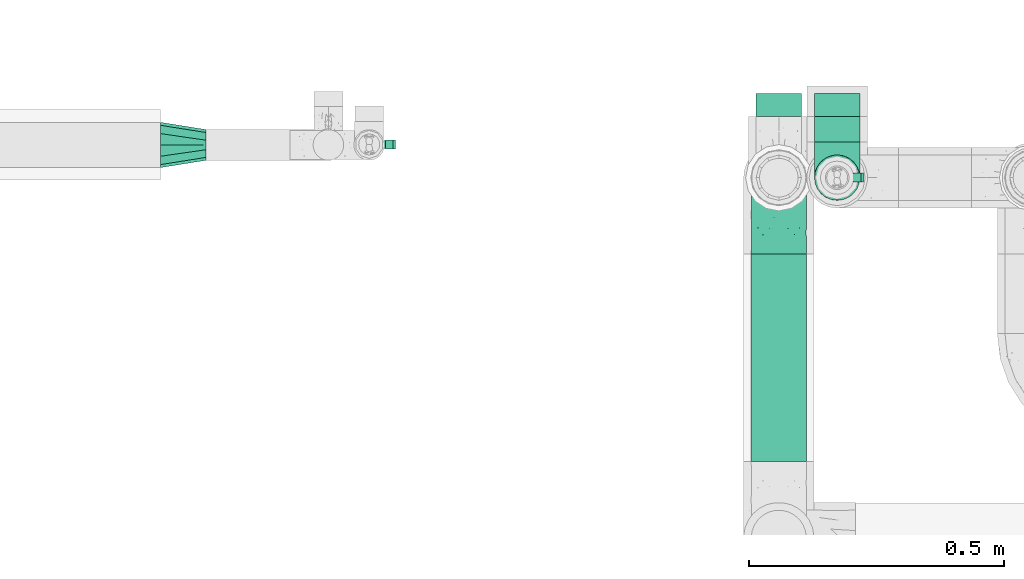
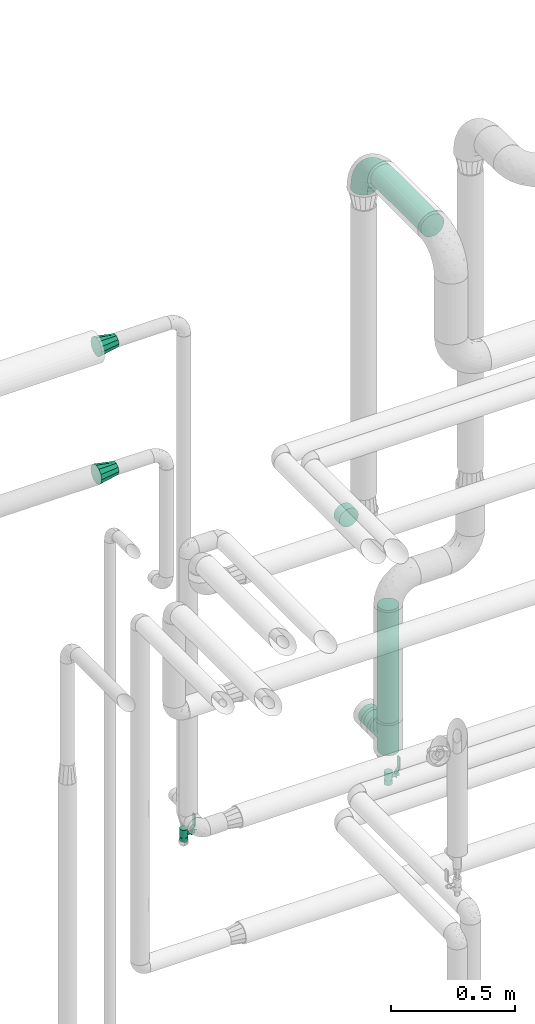
# One storey, part 719 of 827: 6 flow fittings, 3 flow segments, 2 flow controllers.
"""IFC2X3 building model written with IfcOpenShell, lengths in millimetres."""

from ifc_helpers import new_model, entity, si_unit, converted_unit, derived_unit, direction, frame, origin, origin_2d_with_axis, place, context, subcontext, project, spatial, polyline, circle, outline, extrude, faceted_brep, source, transform, mapped, material, material_list, type_object, type_shapes, element, save


model = new_model("IFC2X3")

# Units and contexts
model_context = context("Model", 3, precision=0.01, world=origin(), true_north=direction((6.12303176911189e-17, 1.0)))
body_context = subcontext(model_context, "Body", "Model", "MODEL_VIEW")
ifc_project = project(units=[si_unit("LENGTHUNIT", "METRE", prefix="MILLI"), si_unit("AREAUNIT", "SQUARE_METRE"), si_unit("VOLUMEUNIT", "CUBIC_METRE"), converted_unit("PLANEANGLEUNIT", "DEGREE", entity("IfcRatioMeasure", 0.0174532925199433), si_unit("PLANEANGLEUNIT", "RADIAN"), dimensions=[0, 0, 0, 0, 0, 0, 0]), si_unit("MASSUNIT", "GRAM", prefix="KILO"), derived_unit("MASSDENSITYUNIT", [(si_unit("MASSUNIT", "GRAM", prefix="KILO"), 1), (si_unit("LENGTHUNIT", "METRE"), -3)]), derived_unit("MOMENTOFINERTIAUNIT", [(si_unit("LENGTHUNIT", "METRE"), 4)]), si_unit("TIMEUNIT", "SECOND"), si_unit("FREQUENCYUNIT", "HERTZ"), si_unit("THERMODYNAMICTEMPERATUREUNIT", "DEGREE_CELSIUS"), derived_unit("THERMALTRANSMITTANCEUNIT", [(si_unit("MASSUNIT", "GRAM", prefix="KILO"), 1), (si_unit("THERMODYNAMICTEMPERATUREUNIT", "KELVIN"), -1), (si_unit("TIMEUNIT", "SECOND"), -3)]), derived_unit("VOLUMETRICFLOWRATEUNIT", [(si_unit("LENGTHUNIT", "METRE"), 3), (si_unit("TIMEUNIT", "SECOND"), -1)]), derived_unit("MASSFLOWRATEUNIT", [(si_unit("MASSUNIT", "GRAM", prefix="KILO"), 1), (si_unit("TIMEUNIT", "SECOND"), -1)]), derived_unit("ROTATIONALFREQUENCYUNIT", [(si_unit("TIMEUNIT", "SECOND"), -1)]), si_unit("ELECTRICCURRENTUNIT", "AMPERE"), si_unit("ELECTRICVOLTAGEUNIT", "VOLT"), si_unit("POWERUNIT", "WATT"), si_unit("FORCEUNIT", "NEWTON", prefix="KILO"), si_unit("ILLUMINANCEUNIT", "LUX"), si_unit("LUMINOUSFLUXUNIT", "LUMEN"), si_unit("LUMINOUSINTENSITYUNIT", "CANDELA"), derived_unit("USERDEFINED", [(si_unit("MASSUNIT", "GRAM", prefix="KILO"), -1), (si_unit("LENGTHUNIT", "METRE"), -2), (si_unit("TIMEUNIT", "SECOND"), 3), (si_unit("LUMINOUSFLUXUNIT", "LUMEN"), 1)]), derived_unit("LINEARVELOCITYUNIT", [(si_unit("LENGTHUNIT", "METRE"), 1), (si_unit("TIMEUNIT", "SECOND"), -1)]), si_unit("PRESSUREUNIT", "PASCAL"), derived_unit("USERDEFINED", [(si_unit("LENGTHUNIT", "METRE"), -2), (si_unit("MASSUNIT", "GRAM", prefix="KILO"), 1), (si_unit("TIMEUNIT", "SECOND"), -2)]), derived_unit("LINEARFORCEUNIT", [(si_unit("MASSUNIT", "GRAM", prefix="KILO"), 1), (si_unit("LENGTHUNIT", "METRE"), 1), (si_unit("TIMEUNIT", "SECOND"), -2), (si_unit("LENGTHUNIT", "METRE"), -1)]), derived_unit("PLANARFORCEUNIT", [(si_unit("MASSUNIT", "GRAM", prefix="KILO"), 1), (si_unit("LENGTHUNIT", "METRE"), 1), (si_unit("TIMEUNIT", "SECOND"), -2), (si_unit("LENGTHUNIT", "METRE"), -2)])], contexts=[model_context])

# Site, building, storey
site_placement = place(None, origin())
site = spatial("IfcSite", under=ifc_project, at=site_placement, CompositionType="ELEMENT")
building_placement = place(site_placement, origin())
building = spatial("IfcBuilding", under=site, at=building_placement, CompositionType="ELEMENT")
storey_placement = place(building_placement, frame((0.0, 0.0, 28200.0)))
storey = spatial("IfcBuildingStorey", under=building, at=storey_placement, Name="08", CompositionType="ELEMENT", Elevation=28200.0)

# Flow segments
pipe_segment_type = type_object("IfcPipeSegmentType", PredefinedType="NOTDEFINED")
flow_segment_1_placement = place(storey_placement, frame((55555.45, 18080.1, 3444.4)))
element("IfcFlowSegment", 1, at=flow_segment_1_placement, inside=storey, type_object=pipe_segment_type, context=body_context, shape_type="SweptSolid", body=[
    extrude(circle(Radius=54.0, at=origin_2d_with_axis()), frame((55.6, 0.0, 55.6), z_axis=(0.0, 1.0, 0.0), x_axis=(1.0, 0.0, 0.0)), (0.0, 0.0, 1.0), 405.890503073728),
])
flow_segment_2_placement = place(storey_placement, frame((55679.4, 18705.99, 569.4)))
element("IfcFlowSegment", 2, at=flow_segment_2_placement, inside=storey, type_object=pipe_segment_type, context=body_context, shape_type="SweptSolid", body=[
    extrude(circle(Radius=44.5, at=origin_2d_with_axis()), frame((46.1, 0.0, 46.1), z_axis=(0.0, 1.0, 0.0), x_axis=(1.0, 0.0, 0.0)), (0.0, 0.0, 1.0), 49.9999999999995),
])
flow_segment_3_placement = place(storey_placement, frame((55679.4, 18589.89, 695.5)))
element("IfcFlowSegment", 3, at=flow_segment_3_placement, inside=storey, type_object=pipe_segment_type, context=body_context, shape_type="SweptSolid", body=[
    extrude(circle(Radius=44.5, at=origin_2d_with_axis()), frame((46.1, 46.1, 0.0)), (0.0, 0.0, 1.0), 558.388760911339),
])

# Flow controllers
ifc_material = material()
ifc_material_list = material_list([ifc_material, ifc_material, ifc_material, ifc_material, ifc_material])
valve_type = type_object("IfcValveType", PredefinedType="NOTDEFINED", material=ifc_material_list)
shared_shape_1 = source(origin(), body_context, "Body", "SweptSolid", [
    extrude(circle(Radius=17.5, at=origin_2d_with_axis()), frame((-30.5, 0.0, 0.0), z_axis=(1.0, 0.0, 0.0), x_axis=(0.0, 1.0, 0.0)), (0.0, 0.0, 1.0), 20.3333333333333),
    extrude(circle(Radius=16.0, at=origin_2d_with_axis()), frame((-10.17, 0.0, 0.0), z_axis=(1.0, 0.0, 0.0), x_axis=(0.0, 1.0, 0.0)), (0.0, 0.0, 1.0), 20.3333333333333),
    extrude(circle(Radius=17.5, at=origin_2d_with_axis()), frame((10.17, 0.0, 0.0), z_axis=(1.0, 0.0, 0.0), x_axis=(0.0, 1.0, 0.0)), (0.0, 0.0, 1.0), 20.3333333333333),
    extrude(outline(polyline([(-38.75, -5.0), (-38.75, -10.0), (-17.92, -10.0), (2.08, 5.0), (56.25, 5.0), (56.25, 10.0), (0.42, 10.0), (-19.58, -5.0), (-38.75, -5.0)])), frame((28.75, -8.75, 41.5), z_axis=(0.0, -1.0, 0.0), x_axis=(1.0, 0.0, 0.0)), (0.0, 0.0, -1.0), 17.5),
    extrude(circle(Radius=8.0, at=origin_2d_with_axis()), origin(), (0.0, 0.0, 1.0), 49.0),
])
type_shapes(valve_type, [shared_shape_1])
for number, where, z_axis, x_axis in (
    (4, (54808.07, 18701.2, 400.0), (1.0, 0.0, 0.0), (0.0, 0.0, 1.0)),
    (5, (55725.5, 18635.99, 400.0), (1.0, 0.0, 0.0), (0.0, 0.0, 1.0)),
):
    element("IfcFlowController", number, at=place(storey_placement, frame(where, z_axis=z_axis, x_axis=x_axis)), inside=storey, type_object=valve_type, material=ifc_material, context=body_context, shape_type="MappedRepresentation", body=[
        mapped(shared_shape_1, transform((0.0, 0.0, 0.0), scale=1.0)),
    ])

# Flow fittings
pipe_fitting_type_1 = type_object("IfcPipeFittingType", Name="ADSK_2", PredefinedType="NOTDEFINED", material=ifc_material)
shared_shape_2 = source(origin(), body_context, "Body", "SweptSolid", [
    extrude(circle(Radius=44.5, at=origin_2d_with_axis()), frame((0.0, 0.0, 0.0), z_axis=(1.0, 0.0, 0.0), x_axis=(0.0, 1.0, 0.0)), (0.0, 0.0, 1.0), 45.0000000000003),
])
type_shapes(pipe_fitting_type_1, [shared_shape_2])
for number, where, z_axis, x_axis, name in (
    (6, (55611.05, 18755.99, 1648.17), (1.0, 0.0, 0.0), (0.0, 1.0, 0.0), "ADSK_2"),
    (7, (55725.5, 18755.99, 615.5), (0.0, 0.0, 1.0), (0.0, 1.0, 0.0), "ADSK_2"),
):
    element("IfcFlowFitting", number, at=place(storey_placement, frame(where, z_axis=z_axis, x_axis=x_axis)), inside=storey, type_object=pipe_fitting_type_1, material=ifc_material, Name=name, ObjectType="ADSK_2", context=body_context, shape_type="MappedRepresentation", body=[
        mapped(shared_shape_2, transform((0.0, 0.0, 0.0), scale=1.0)),
    ])
pipe_fitting_type_2 = type_object("IfcPipeFittingType", Name="ADSK_2", PredefinedType="NOTDEFINED", material=ifc_material)
shared_shape_3 = source(origin(), body_context, "Body", "Brep", [
    faceted_brep([(-150.0, 13.98, -52.16), (-150.0, 0.0, -54.0), (-150.0, -13.98, -52.16), (-150.0, -27.0, -46.77), (-150.0, -38.18, -38.18), (-150.0, -46.77, -27.0), (-150.0, -52.16, -13.98), (-150.0, -54.0, 0.0), (-150.0, -52.16, 13.98), (-150.0, -46.77, 27.0), (-150.0, -38.18, 38.18), (-150.0, -27.0, 46.77), (-150.0, -13.98, 52.16), (-150.0, 0.0, 54.0), (-150.0, 13.98, 52.16), (-150.0, 27.0, 46.77), (-150.0, 38.18, 38.18), (-150.0, 46.77, 27.0), (-150.0, 52.16, 13.98), (-150.0, 54.0, 0.0), (-150.0, 52.16, -13.98), (-150.0, 46.77, -27.0), (-150.0, 38.18, -38.18), (-150.0, 27.0, -46.77), (-46.77, 150.0, -27.0), (-52.16, 150.0, -13.98), (-54.0, 150.0, 0.0), (-52.16, 150.0, 13.98), (-46.77, 150.0, 27.0), (-38.18, 150.0, 38.18), (-27.0, 150.0, 46.77), (-13.98, 150.0, 52.16), (0.0, 150.0, 54.0), (13.98, 150.0, 52.16), (27.0, 150.0, 46.77), (38.18, 150.0, 38.18), (46.77, 150.0, 27.0), (52.16, 150.0, 13.98), (54.0, 150.0, 0.0), (52.16, 150.0, -13.98), (46.77, 150.0, -27.0), (38.18, 150.0, -38.18), (27.0, 150.0, -46.77), (13.98, 150.0, -52.16), (0.0, 150.0, -54.0), (-13.98, 150.0, -52.16), (-27.0, 150.0, -46.77), (-38.18, 150.0, -38.18), (-23.02, 116.05, 50.71), (-10.79, 106.96, 53.83), (-99.79, -44.6, 17.82), (-104.61, -48.89, 0.0), (-111.52, -18.45, 48.95), (-64.27, -5.9, 46.22), (-79.66, 4.7, 52.78), (-22.81, -9.49, 0.0), (-44.33, -22.22, 14.35), (-61.49, -33.8, 0.0), (-111.02, -40.26, 31.0), (-106.96, 10.79, 53.83), (-75.79, 19.35, 54.0), (-83.79, 28.63, 52.71), (-6.35, 6.35, 9.57), (22.22, 44.33, 14.35), (-8.95, 8.95, 21.66), (-70.7, -34.05, 19.37), (-77.79, -39.89, 9.53), (-98.78, -28.03, 40.91), (-35.45, -0.96, 36.82), (-24.08, 24.08, 46.13), (-116.99, -5.61, 53.23), (-84.48, 39.18, 49.64), (-116.05, 23.02, 50.71), (28.03, 98.78, 40.91), (-30.84, 79.95, 52.7), (-19.51, 75.72, 54.0), (-52.23, 125.53, 22.23), (-63.5, 102.33, 17.08), (-52.58, 23.63, 53.15), (-23.76, 41.59, 51.45), (-36.39, 47.25, 53.91), (-58.7, 120.33, 0.0), (-125.53, 52.23, 22.23), (-102.33, 63.5, 17.08), (-120.33, 58.7, 0.0), (-59.32, 99.83, 27.68), (-79.36, 79.36, 20.15), (-75.61, 75.61, 30.15), (-114.52, 47.22, 34.83), (-126.22, 33.98, 43.81), (-93.57, 72.33, 0.0), (-47.51, 113.57, 34.88), (18.45, 111.52, 48.95), (5.61, 116.99, 53.23), (48.89, 104.61, 0.0), (44.6, 99.79, 17.82), (37.15, 71.79, 11.16), (5.9, 64.27, 46.22), (-4.7, 79.66, 52.78), (35.09, 74.65, 20.78), (40.26, 111.02, 31.0), (26.44, 65.11, 28.6), (-65.6, -16.94, 39.27), (-65.11, -26.44, 28.6), (-81.51, 81.51, 9.56), (-72.33, 93.57, 0.0), (9.49, 22.81, 0.0), (-35.64, -11.82, 24.43), (-34.23, 124.56, 43.88), (-43.22, 94.57, 45.11), (-69.02, 56.15, 47.3), (-59.26, 74.56, 43.5), (-78.28, 61.88, 39.9), (18.71, 65.93, 37.87), (0.96, 35.45, 36.82), (-59.2, 87.93, 36.27), (33.8, 61.49, 0.0), (-97.33, 42.02, 44.99), (-99.65, 59.35, 27.78), (-56.16, 9.04, 50.42), (11.82, 35.64, 24.43), (-49.6, 72.87, 48.67), (-34.04, 93.29, 49.78), (-57.05, 51.22, 52.06), (-124.56, 34.23, -43.88), (-98.78, -28.03, -40.91), (-79.66, 4.7, -52.78), (-116.99, -5.61, -53.23), (-106.96, 10.79, -53.83), (-99.83, 59.32, -27.68), (-113.57, 47.51, -34.88), (-125.53, 52.23, -22.23), (-116.05, 23.02, -50.71), (-79.95, 30.84, -52.7), (-47.22, 114.52, -34.83), (-102.33, 63.5, -17.08), (40.26, 111.02, -31.0), (-81.51, 81.51, -9.56), (-52.23, 125.53, -22.23), (-94.57, 43.22, -45.11), (-64.27, -5.9, -46.22), (-35.45, -0.96, -36.82), (-65.93, -18.71, -37.87), (-99.79, -44.6, -17.82), (-47.25, 36.39, -53.91), (-75.72, 19.51, -54.0), (-39.18, 84.48, -49.64), (-23.02, 116.05, -50.71), (-28.63, 83.79, -52.71), (-111.02, -40.26, -31.0), (-10.79, 106.96, -53.83), (-19.35, 75.79, -54.0), (-44.33, -22.22, -14.35), (-8.95, 8.95, -21.66), (-6.35, 6.35, -9.57), (-71.79, -37.15, -11.16), (-61.88, 78.28, -39.9), (-74.56, 59.26, -43.5), (-87.93, 59.2, -36.27), (-74.65, -35.09, -20.78), (-65.11, -26.44, -28.6), (0.96, 35.45, -36.82), (-63.5, 102.33, -17.08), (-79.36, 79.36, -20.15), (18.45, 111.52, -48.95), (5.9, 64.27, -46.22), (-4.7, 79.66, -52.78), (-75.61, 75.61, -30.15), (-33.98, 126.22, -43.81), (5.61, 116.99, -53.23), (-23.63, 52.58, -53.15), (-41.59, 23.76, -51.45), (22.22, 44.33, -14.35), (-56.15, 69.02, -47.3), (28.03, 98.78, -40.91), (39.89, 77.79, -9.53), (34.05, 70.7, -19.37), (-111.52, -18.45, -48.95), (44.6, 99.79, -17.82), (26.44, 65.11, -28.6), (11.82, 35.64, -24.43), (16.94, 65.6, -39.27), (-42.02, 97.33, -44.99), (-59.35, 99.65, -27.78), (-24.08, 24.08, -46.13), (-9.04, 56.16, -50.42), (-35.64, -11.82, -24.43), (-72.87, 49.6, -48.67), (-93.29, 34.04, -49.78), (-51.22, 57.05, -52.06)], [[[0, 1, 2, 3, 4, 5, 6, 7, 8, 9, 10, 11, 12, 13, 14, 15, 16, 17, 18, 19, 20, 21, 22, 23]], [[24, 25, 26, 27, 28, 29, 30, 31, 32, 33, 34, 35, 36, 37, 38, 39, 40, 41, 42, 43, 44, 45, 46, 47]], [[31, 48, 49]], [[50, 8, 51]], [[52, 53, 54]], [[8, 50, 9]], [[8, 7, 51]], [[55, 56, 57]], [[58, 9, 50]], [[59, 60, 61]], [[62, 63, 64]], [[65, 66, 56]], [[11, 10, 67]], [[53, 68, 69]], [[67, 52, 11]], [[70, 59, 13]], [[71, 72, 61]], [[73, 35, 34]], [[74, 75, 49]], [[72, 15, 14]], [[13, 59, 14]], [[76, 27, 77]], [[12, 70, 13]], [[78, 79, 80]], [[27, 81, 77]], [[18, 82, 83]], [[72, 14, 59]], [[84, 19, 18]], [[85, 86, 87]], [[88, 16, 89]], [[84, 83, 90]], [[84, 18, 83]], [[15, 89, 16]], [[85, 91, 76]], [[92, 73, 34]], [[49, 32, 31]], [[93, 33, 32]], [[31, 30, 48]], [[94, 95, 96]], [[94, 37, 95]], [[73, 92, 97]], [[98, 93, 49]], [[11, 52, 12]], [[36, 95, 37]], [[99, 100, 101]], [[95, 36, 100]], [[63, 96, 99]], [[100, 36, 35]], [[102, 53, 67]], [[38, 37, 94]], [[92, 34, 33]], [[103, 67, 58]], [[81, 27, 26]], [[104, 105, 90]], [[106, 62, 55]], [[9, 58, 10]], [[91, 29, 28]], [[77, 81, 105]], [[107, 103, 65]], [[49, 48, 74]], [[83, 86, 104]], [[108, 91, 109]], [[16, 88, 17]], [[110, 111, 112]], [[113, 114, 101]], [[108, 30, 29]], [[113, 97, 114]], [[112, 111, 115]], [[66, 51, 57]], [[63, 106, 116]], [[74, 80, 75]], [[82, 18, 17]], [[76, 28, 27]], [[115, 91, 85]], [[112, 88, 117]], [[118, 83, 82]], [[58, 50, 65]], [[67, 10, 58]], [[35, 73, 100]], [[101, 100, 73]], [[53, 52, 67]], [[70, 52, 54]], [[102, 103, 68]], [[119, 78, 54]], [[93, 92, 33]], [[98, 79, 97]], [[98, 97, 92]], [[97, 69, 114]], [[56, 55, 62]], [[56, 107, 65]], [[96, 63, 116]], [[63, 99, 120]], [[108, 48, 30]], [[121, 74, 122]], [[61, 72, 59]], [[89, 72, 117]], [[107, 68, 103]], [[64, 120, 114]], [[69, 68, 114]], [[64, 114, 68]], [[122, 74, 48]], [[74, 123, 80]], [[123, 61, 60]], [[80, 60, 78]], [[49, 93, 32]], [[92, 93, 98]], [[52, 70, 12]], [[59, 70, 54]], [[59, 54, 60]], [[123, 110, 71]], [[78, 60, 54]], [[123, 60, 80]], [[119, 54, 53]], [[78, 119, 79]], [[97, 79, 69]], [[98, 80, 79]], [[53, 69, 119]], [[79, 119, 69]], [[91, 108, 29]], [[108, 109, 122]], [[85, 76, 77]], [[91, 28, 76]], [[86, 85, 77]], [[115, 85, 87]], [[112, 115, 87]], [[109, 91, 115]], [[112, 87, 118]], [[112, 117, 110]], [[71, 110, 117]], [[122, 109, 121]], [[17, 88, 82]], [[118, 87, 86]], [[82, 88, 118]], [[112, 118, 88]], [[80, 98, 75]], [[98, 49, 75]], [[111, 110, 121]], [[115, 111, 109]], [[72, 89, 15]], [[88, 89, 117]], [[72, 71, 117]], [[123, 71, 61]], [[77, 105, 104]], [[118, 86, 83]], [[83, 104, 90]], [[77, 104, 86]], [[63, 62, 106]], [[56, 62, 64]], [[56, 64, 107]], [[68, 107, 64]], [[58, 65, 103]], [[66, 65, 50]], [[51, 66, 50]], [[56, 66, 57]], [[94, 96, 116]], [[99, 96, 95]], [[100, 99, 95]], [[99, 101, 120]], [[114, 120, 101]], [[64, 63, 120]], [[103, 102, 67]], [[68, 53, 102]], [[101, 73, 113]], [[97, 113, 73]], [[108, 122, 48]], [[111, 121, 109]], [[110, 123, 121]], [[74, 121, 123]], [[22, 124, 23]], [[125, 4, 3]], [[126, 127, 128]], [[129, 130, 131]], [[132, 133, 128]], [[128, 1, 0]], [[19, 84, 20]], [[47, 134, 24]], [[90, 135, 84]], [[40, 136, 41]], [[105, 137, 90]], [[131, 20, 135]], [[138, 25, 24]], [[139, 124, 130]], [[130, 22, 21]], [[140, 141, 142]], [[5, 143, 6]], [[133, 144, 145]], [[51, 7, 6]], [[146, 147, 148]], [[143, 5, 149]], [[150, 151, 148]], [[57, 152, 55]], [[153, 154, 152]], [[20, 84, 135]], [[143, 51, 6]], [[143, 155, 51]], [[156, 157, 158]], [[127, 2, 1]], [[159, 149, 160]], [[0, 23, 132]], [[141, 161, 153]], [[162, 163, 137]], [[42, 164, 43]], [[164, 165, 166]], [[44, 150, 45]], [[163, 167, 129]], [[25, 81, 26]], [[0, 132, 128]], [[162, 25, 138]], [[147, 46, 45]], [[47, 168, 134]], [[43, 169, 44]], [[170, 171, 144]], [[81, 25, 162]], [[46, 168, 47]], [[106, 172, 116]], [[150, 147, 45]], [[173, 157, 156]], [[42, 174, 164]], [[55, 154, 106]], [[174, 42, 41]], [[169, 150, 44]], [[175, 172, 176]], [[125, 3, 177]], [[133, 145, 128]], [[178, 40, 39]], [[179, 174, 136]], [[38, 94, 39]], [[152, 155, 159]], [[149, 5, 4]], [[178, 39, 94]], [[175, 94, 116]], [[40, 178, 136]], [[177, 3, 2]], [[179, 176, 180]], [[125, 177, 140]], [[162, 105, 81]], [[181, 165, 174]], [[160, 142, 141]], [[131, 21, 20]], [[158, 130, 129]], [[156, 134, 182]], [[183, 162, 138]], [[4, 125, 149]], [[160, 149, 125]], [[136, 178, 176]], [[174, 41, 136]], [[127, 177, 2]], [[126, 171, 140]], [[126, 140, 177]], [[140, 184, 141]], [[165, 164, 174]], [[169, 164, 166]], [[181, 179, 161]], [[185, 170, 166]], [[155, 152, 57]], [[152, 159, 186]], [[172, 106, 154]], [[172, 180, 176]], [[124, 132, 23]], [[187, 133, 188]], [[148, 147, 150]], [[168, 147, 182]], [[161, 184, 165]], [[186, 141, 153]], [[161, 179, 180]], [[141, 184, 161]], [[188, 133, 132]], [[133, 189, 144]], [[189, 148, 151]], [[144, 151, 170]], [[128, 127, 1]], [[177, 127, 126]], [[164, 169, 43]], [[150, 169, 166]], [[150, 166, 151]], [[189, 173, 146]], [[170, 151, 166]], [[189, 151, 144]], [[185, 166, 165]], [[170, 185, 171]], [[140, 171, 184]], [[126, 144, 171]], [[165, 184, 185]], [[171, 185, 184]], [[130, 124, 22]], [[124, 139, 188]], [[129, 131, 135]], [[130, 21, 131]], [[163, 129, 135]], [[158, 129, 167]], [[156, 158, 167]], [[139, 130, 158]], [[156, 167, 183]], [[156, 182, 173]], [[146, 173, 182]], [[188, 139, 187]], [[24, 134, 138]], [[183, 167, 163]], [[138, 134, 183]], [[156, 183, 134]], [[144, 126, 145]], [[126, 128, 145]], [[157, 173, 187]], [[158, 157, 139]], [[147, 168, 46]], [[134, 168, 182]], [[147, 146, 182]], [[189, 146, 148]], [[135, 90, 137]], [[183, 163, 162]], [[162, 137, 105]], [[135, 137, 163]], [[152, 154, 55]], [[172, 154, 153]], [[51, 155, 57]], [[159, 155, 143]], [[149, 159, 143]], [[159, 160, 186]], [[141, 186, 160]], [[153, 152, 186]], [[172, 153, 180]], [[161, 180, 153]], [[136, 176, 179]], [[175, 176, 178]], [[94, 175, 178]], [[172, 175, 116]], [[160, 125, 142]], [[140, 142, 125]], [[179, 181, 174]], [[161, 165, 181]], [[124, 188, 132]], [[157, 187, 139]], [[173, 189, 187]], [[133, 187, 189]]]),
])
type_shapes(pipe_fitting_type_2, [shared_shape_3])
flow_fitting_1_placement = place(storey_placement, frame((55611.05, 18635.99, 3499.74), z_axis=(-1.0, 0.0, 0.0), x_axis=(0.0, 1.0, 0.0)))
element("IfcFlowFitting", 8, at=flow_fitting_1_placement, inside=storey, type_object=pipe_fitting_type_2, material=ifc_material, Name="ADSK_2", ObjectType="ADSK_2", context=body_context, shape_type="MappedRepresentation", body=[
    mapped(shared_shape_3, transform((0.0, 0.0, 0.0), scale=1.0)),
])
pipe_fitting_type_3 = type_object("IfcPipeFittingType", Name="ADSK_2", PredefinedType="NOTDEFINED", material=ifc_material)
shared_shape_4 = source(origin(), body_context, "Body", "Brep", [
    faceted_brep([(-80.0, 22.25, -38.54), (-80.0, 11.52, -42.98), (-80.0, 0.0, -44.5), (-80.0, -11.52, -42.98), (-80.0, -22.25, -38.54), (-80.0, -26.86, -35.0), (-80.0, -31.47, -31.47), (-80.0, -35.0, -26.86), (-80.0, -38.54, -22.25), (-80.0, -40.76, -16.88), (-80.0, -42.98, -11.52), (-80.0, -44.5, 0.0), (-80.0, -42.98, 11.52), (-80.0, -40.76, 16.88), (-80.0, -38.54, 22.25), (-80.0, -35.0, 26.86), (-80.0, -31.47, 31.47), (-80.0, -26.86, 35.0), (-80.0, -22.25, 38.54), (-80.0, -11.52, 42.98), (-80.0, 0.0, 44.5), (-80.0, 11.52, 42.98), (-80.0, 22.25, 38.54), (-80.0, 31.47, 31.47), (-80.0, 38.54, 22.25), (-80.0, 42.98, 11.52), (-80.0, 44.5, 0.0), (-80.0, 42.98, -11.52), (-80.0, 38.54, -22.25), (-80.0, 31.47, -31.47), (80.0, 0.0, -44.5), (80.0, 11.52, -42.98), (80.0, 22.25, -38.54), (80.0, 31.47, -31.47), (80.0, 38.54, -22.25), (80.0, 42.98, -11.52), (80.0, 44.5, 0.0), (80.0, 42.98, 11.52), (80.0, 38.54, 22.25), (80.0, 31.47, 31.47), (80.0, 22.25, 38.54), (80.0, 11.52, 42.98), (80.0, 0.0, 44.5), (80.0, -11.52, 42.98), (80.0, -22.25, 38.54), (80.0, -26.86, 35.0), (80.0, -31.47, 31.47), (80.0, -35.0, 26.86), (80.0, -38.54, 22.25), (80.0, -40.76, 16.88), (80.0, -42.98, 11.52), (80.0, -44.5, 0.0), (80.0, -42.98, -11.52), (80.0, -40.76, -16.88), (80.0, -38.54, -22.25), (80.0, -35.0, -26.86), (80.0, -31.47, -31.47), (80.0, -26.86, -35.0), (80.0, -22.25, -38.54), (80.0, -11.52, -42.98), (43.26, -43.26, 10.45), (44.5, -44.5, 0.0), (-43.26, -43.26, 10.45), (-44.5, -44.5, 0.0), (41.54, -41.54, 15.16), (39.82, -39.82, 19.87), (22.0, -22.0, 38.68), (34.79, -34.79, 27.75), (28.72, -28.72, 33.99), (-41.54, -41.54, 15.16), (37.3, -37.3, 23.81), (-39.82, -39.82, 19.87), (-22.0, -22.0, 38.68), (-34.79, -34.79, 27.75), (-28.72, -28.72, 33.99), (-37.3, -37.3, 23.81), (-14.86, -14.86, 41.95), (7.48, -7.48, 43.87), (14.86, -14.86, 41.95), (0.0, 0.0, 44.5), (-7.48, -7.48, 43.87), (7.48, -7.48, -43.87), (0.0, 0.0, -44.5), (14.86, -14.86, -41.95), (-28.72, -28.72, -33.99), (-7.48, -7.48, -43.87), (-41.54, -41.54, -15.16), (-43.26, -43.26, -10.45), (-37.3, -37.3, -23.81), (-34.79, -34.79, -27.75), (-14.86, -14.86, -41.95), (22.0, -22.0, -38.68), (28.72, -28.72, -33.99), (39.82, -39.82, -19.87), (37.3, -37.3, -23.81), (34.79, -34.79, -27.75), (-39.82, -39.82, -19.87), (43.26, -43.26, -10.45), (41.54, -41.54, -15.16), (-22.0, -22.0, -38.68), (38.54, -70.0, -22.25), (42.98, -70.0, -11.52), (44.5, -70.0, 0.0), (42.98, -70.0, 11.52), (38.54, -70.0, 22.25), (31.47, -70.0, 31.47), (22.25, -70.0, 38.54), (11.52, -70.0, 42.98), (0.0, -70.0, 44.5), (-11.52, -70.0, 42.98), (-22.25, -70.0, 38.54), (-31.47, -70.0, 31.47), (-38.54, -70.0, 22.25), (-42.98, -70.0, 11.52), (-44.5, -70.0, 0.0), (-42.98, -70.0, -11.52), (-38.54, -70.0, -22.25), (-31.47, -70.0, -31.47), (-22.25, -70.0, -38.54), (-11.52, -70.0, -42.98), (0.0, -70.0, -44.5), (11.52, -70.0, -42.98), (22.25, -70.0, -38.54), (31.47, -70.0, -31.47)], [[[0, 1, 2, 3, 4, 5, 6, 7, 8, 9, 10, 11, 12, 13, 14, 15, 16, 17, 18, 19, 20, 21, 22, 23, 24, 25, 26, 27, 28, 29]], [[30, 31, 32, 33, 34, 35, 36, 37, 38, 39, 40, 41, 42, 43, 44, 45, 46, 47, 48, 49, 50, 51, 52, 53, 54, 55, 56, 57, 58, 59]], [[51, 50, 60]], [[60, 61, 51]], [[62, 11, 63]], [[50, 49, 64]], [[49, 48, 65]], [[44, 66, 45]], [[46, 67, 47]], [[67, 46, 68]], [[12, 69, 13]], [[48, 70, 65]], [[50, 64, 60]], [[68, 46, 45]], [[71, 13, 69]], [[11, 62, 12]], [[12, 62, 69]], [[49, 65, 64]], [[72, 18, 17]], [[73, 74, 16]], [[15, 14, 75]], [[16, 74, 17]], [[72, 76, 18]], [[15, 75, 73]], [[70, 47, 67]], [[45, 66, 68]], [[43, 42, 77]], [[14, 71, 75]], [[66, 44, 78]], [[77, 78, 43]], [[73, 16, 15]], [[77, 42, 79]], [[80, 79, 20]], [[78, 44, 43]], [[24, 23, 39, 38]], [[25, 24, 38, 37]], [[22, 21, 41, 40]], [[23, 22, 40, 39]], [[41, 21, 20, 79, 42]], [[26, 25, 37, 36]], [[71, 14, 13]], [[80, 19, 76]], [[19, 80, 20]], [[19, 18, 76]], [[72, 17, 74]], [[47, 70, 48]], [[33, 29, 28, 34]], [[28, 27, 35, 34]], [[0, 29, 33, 32]], [[26, 36, 35, 27]], [[30, 59, 81]], [[31, 30, 82, 2, 1]], [[81, 59, 83]], [[84, 6, 5]], [[32, 31, 1, 0]], [[59, 58, 83]], [[30, 81, 82]], [[82, 85, 2]], [[10, 86, 87]], [[88, 7, 89]], [[85, 90, 3]], [[2, 85, 3]], [[90, 4, 3]], [[91, 57, 92]], [[57, 56, 92]], [[54, 93, 94]], [[91, 58, 57]], [[95, 92, 56]], [[9, 96, 86]], [[54, 94, 55]], [[58, 91, 83]], [[52, 97, 98]], [[97, 52, 51]], [[93, 53, 98]], [[61, 97, 51]], [[87, 63, 11]], [[94, 95, 55]], [[84, 5, 99]], [[7, 88, 8]], [[5, 4, 99]], [[6, 84, 89]], [[6, 89, 7]], [[93, 54, 53]], [[99, 4, 90]], [[52, 98, 53]], [[10, 9, 86]], [[96, 9, 8]], [[10, 87, 11]], [[96, 8, 88]], [[95, 56, 55]], [[100, 101, 102, 103, 104, 105, 106, 107, 108, 109, 110, 111, 112, 113, 114, 115, 116, 117, 118, 119, 120, 121, 122, 123]], [[62, 63, 114]], [[113, 62, 114]], [[111, 110, 74]], [[73, 112, 111]], [[71, 113, 112]], [[76, 110, 109]], [[113, 71, 69, 62]], [[74, 73, 111]], [[112, 73, 75, 71]], [[76, 72, 110]], [[108, 79, 80]], [[76, 109, 80]], [[74, 110, 72]], [[80, 109, 108]], [[77, 108, 107]], [[106, 78, 107]], [[104, 103, 65]], [[67, 105, 104]], [[68, 106, 105]], [[60, 103, 102]], [[68, 66, 106]], [[78, 77, 107]], [[66, 78, 106]], [[61, 60, 102]], [[104, 65, 70, 67]], [[103, 60, 64, 65]], [[68, 105, 67]], [[108, 77, 79]], [[61, 102, 97]], [[101, 97, 102]], [[95, 100, 123]], [[123, 122, 92]], [[93, 101, 100]], [[83, 122, 121]], [[101, 93, 98, 97]], [[92, 95, 123]], [[100, 95, 94, 93]], [[83, 91, 122]], [[120, 82, 81]], [[83, 121, 81]], [[92, 122, 91]], [[81, 121, 120]], [[85, 120, 119]], [[118, 90, 119]], [[116, 115, 96]], [[89, 117, 116]], [[84, 118, 117]], [[87, 115, 114]], [[84, 99, 118]], [[90, 85, 119]], [[99, 90, 118]], [[63, 87, 114]], [[116, 96, 88, 89]], [[115, 87, 86, 96]], [[84, 117, 89]], [[120, 85, 82]]]),
])
type_shapes(pipe_fitting_type_3, [shared_shape_4])
flow_fitting_2_placement = place(storey_placement, frame((55725.5, 18635.99, 615.5), z_axis=(1.0, 0.0, 0.0), x_axis=(0.0, 0.0, 1.0)))
element("IfcFlowFitting", 9, at=flow_fitting_2_placement, inside=storey, type_object=pipe_fitting_type_3, material=ifc_material, Name="ADSK_2", ObjectType="ADSK_2", context=body_context, shape_type="MappedRepresentation", body=[
    mapped(shared_shape_4, transform((0.0, 0.0, 0.0), scale=1.0)),
])
pipe_fitting_type_4 = type_object("IfcPipeFittingType", Name="ADSK_1", PredefinedType="NOTDEFINED", material=ifc_material)
shared_shape_5 = source(origin(), body_context, "Body", "Brep", [
    faceted_brep([(89.0, -44.45, 0.0), (89.0, -42.1, -8.76), (89.0, -38.49, -22.22), (89.0, -30.36, -30.36), (89.0, -22.23, -38.49), (89.0, -11.11, -41.47), (89.0, 0.0, -44.45), (89.0, 11.11, -41.47), (89.0, 22.22, -38.49), (89.0, 30.36, -30.36), (89.0, 38.49, -22.22), (89.0, 42.1, -8.76), (89.0, 44.45, 0.0), (89.0, 42.1, 8.76), (89.0, 38.49, 22.23), (89.0, 30.36, 30.36), (89.0, 22.22, 38.49), (89.0, 11.11, 41.47), (89.0, 0.0, 44.45), (89.0, -11.11, 41.47), (89.0, -22.23, 38.49), (89.0, -30.36, 30.36), (89.0, -38.49, 22.23), (89.0, -42.1, 8.76), (0.0, 30.15, 0.0), (0.0, 27.27, -8.86), (0.0, 24.39, -17.72), (0.0, 16.85, -23.2), (0.0, 9.32, -28.67), (0.0, 0.0, -28.67), (0.0, -9.32, -28.67), (0.0, -16.85, -23.2), (0.0, -24.39, -17.72), (0.0, -27.27, -8.86), (0.0, -30.15, 0.0), (0.0, -27.27, 8.86), (0.0, -24.39, 17.72), (0.0, -16.85, 23.2), (0.0, -9.32, 28.67), (0.0, 0.0, 28.67), (0.0, 9.32, 28.67), (0.0, 16.85, 23.2), (0.0, 24.39, 17.72), (0.0, 27.27, 8.86)], [[[0, 1, 2, 3, 4, 5, 6, 7, 8, 9, 10, 11, 12, 13, 14, 15, 16, 17, 18, 19, 20, 21, 22, 23]], [[24, 25, 26, 27, 28, 29, 30, 31, 32, 33, 34, 35, 36, 37, 38, 39, 40, 41, 42, 43]], [[2, 33, 32]], [[28, 7, 29]], [[29, 5, 30]], [[24, 12, 11]], [[3, 32, 31]], [[34, 1, 0]], [[1, 34, 33]], [[8, 28, 27]], [[2, 1, 33]], [[31, 4, 3]], [[2, 32, 3]], [[11, 25, 24]], [[26, 10, 9]], [[10, 25, 11]], [[28, 8, 7]], [[27, 26, 9]], [[26, 25, 10]], [[31, 30, 4]], [[8, 27, 9]], [[29, 7, 6]], [[5, 29, 6]], [[5, 4, 30]], [[14, 43, 42]], [[38, 19, 39]], [[39, 17, 40]], [[34, 0, 23]], [[15, 42, 41]], [[24, 13, 12]], [[13, 24, 43]], [[20, 38, 37]], [[14, 13, 43]], [[41, 16, 15]], [[14, 42, 15]], [[23, 35, 34]], [[36, 22, 21]], [[22, 35, 23]], [[38, 20, 19]], [[37, 36, 21]], [[36, 35, 22]], [[41, 40, 16]], [[20, 37, 21]], [[39, 19, 18]], [[17, 39, 18]], [[17, 16, 40]]]),
])
type_shapes(pipe_fitting_type_4, [shared_shape_5])
flow_fitting_3_placement = place(storey_placement, frame((54488.07, 18700.2, 2320.0), z_axis=(0.0, 0.0, 1.0), x_axis=(-1.0, 0.0, 0.0)))
element("IfcFlowFitting", 10, at=flow_fitting_3_placement, inside=storey, type_object=pipe_fitting_type_4, material=ifc_material, Name="ADSK_1", ObjectType="ADSK_1", context=body_context, shape_type="MappedRepresentation", body=[
    mapped(shared_shape_5, transform((0.0, 0.0, 0.0), scale=1.0)),
])
pipe_fitting_type_5 = type_object("IfcPipeFittingType", Name="ADSK_1", PredefinedType="NOTDEFINED", material=ifc_material)
shared_shape_6 = source(origin(), body_context, "Body", "Brep", [
    faceted_brep([(89.0, -24.39, 17.72), (89.0, -27.27, 8.86), (89.0, -30.15, 0.0), (89.0, -27.27, -8.86), (89.0, -24.39, -17.72), (89.0, -16.85, -23.2), (89.0, -9.32, -28.67), (89.0, 0.0, -28.67), (89.0, 9.32, -28.67), (89.0, 16.85, -23.2), (89.0, 24.39, -17.72), (89.0, 27.27, -8.86), (89.0, 30.15, 0.0), (89.0, 27.27, 8.86), (89.0, 24.39, 17.72), (89.0, 16.85, 23.2), (89.0, 9.32, 28.67), (89.0, 0.0, 28.67), (89.0, -9.32, 28.67), (89.0, -16.85, 23.2), (0.0, 11.11, 41.47), (0.0, 22.22, 38.49), (0.0, 30.36, 30.36), (0.0, 38.49, 22.23), (0.0, 42.1, 8.76), (0.0, 44.45, 0.0), (0.0, 42.1, -8.76), (0.0, 38.49, -22.23), (0.0, 30.36, -30.36), (0.0, 22.23, -38.49), (0.0, 11.11, -41.47), (0.0, 0.0, -44.45), (0.0, -11.11, -41.47), (0.0, -22.23, -38.49), (0.0, -30.36, -30.36), (0.0, -38.49, -22.22), (0.0, -42.1, -8.76), (0.0, -44.45, 0.0), (0.0, -42.1, 8.76), (0.0, -38.49, 22.22), (0.0, -30.36, 30.36), (0.0, -22.22, 38.49), (0.0, -11.11, 41.47), (0.0, 0.0, 44.45)], [[[0, 1, 2, 3, 4, 5, 6, 7, 8, 9, 10, 11, 12, 13, 14, 15, 16, 17, 18, 19]], [[20, 21, 22, 23, 24, 25, 26, 27, 28, 29, 30, 31, 32, 33, 34, 35, 36, 37, 38, 39, 40, 41, 42, 43]], [[28, 9, 29]], [[27, 10, 28]], [[9, 28, 10]], [[27, 11, 10]], [[26, 12, 11]], [[33, 6, 5]], [[9, 8, 29]], [[30, 29, 8]], [[6, 32, 7]], [[8, 7, 30]], [[4, 34, 5]], [[2, 37, 36]], [[32, 31, 7]], [[2, 36, 3]], [[27, 26, 11]], [[6, 33, 32]], [[12, 26, 25]], [[3, 35, 4]], [[4, 35, 34]], [[35, 3, 36]], [[33, 5, 34]], [[30, 7, 31]], [[40, 19, 41]], [[39, 0, 40]], [[19, 40, 0]], [[39, 1, 0]], [[38, 2, 1]], [[21, 16, 15]], [[19, 18, 41]], [[42, 41, 18]], [[16, 20, 17]], [[18, 17, 42]], [[14, 22, 15]], [[12, 25, 24]], [[20, 43, 17]], [[12, 24, 13]], [[39, 38, 1]], [[16, 21, 20]], [[2, 38, 37]], [[13, 23, 14]], [[14, 23, 22]], [[23, 13, 24]], [[21, 15, 22]], [[42, 17, 43]]]),
])
type_shapes(pipe_fitting_type_5, [shared_shape_6])
flow_fitting_4_placement = place(storey_placement, frame((54399.07, 18700.2, 2950.0)))
element("IfcFlowFitting", 11, at=flow_fitting_4_placement, inside=storey, type_object=pipe_fitting_type_5, material=ifc_material, Name="ADSK_1", ObjectType="ADSK_1", context=body_context, shape_type="MappedRepresentation", body=[
    mapped(shared_shape_6, transform((0.0, 0.0, 0.0), scale=1.0)),
])

save(model, "model.ifc")
